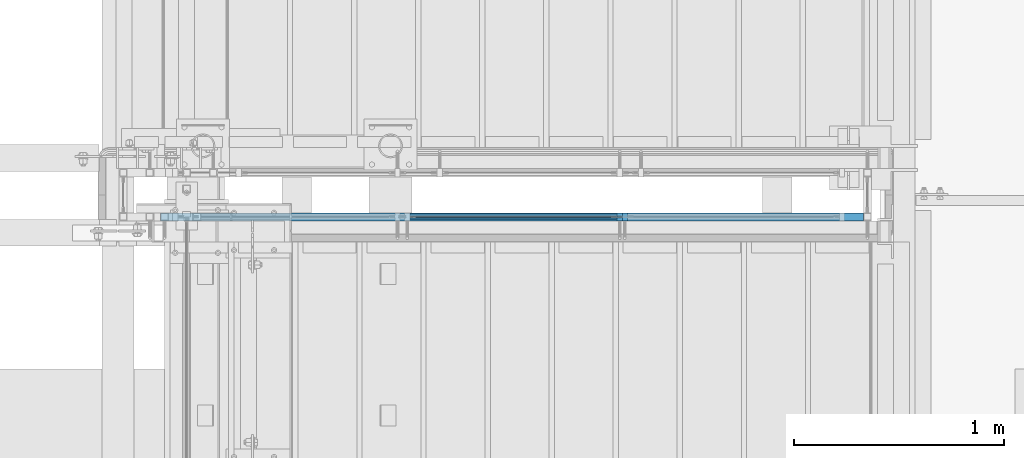
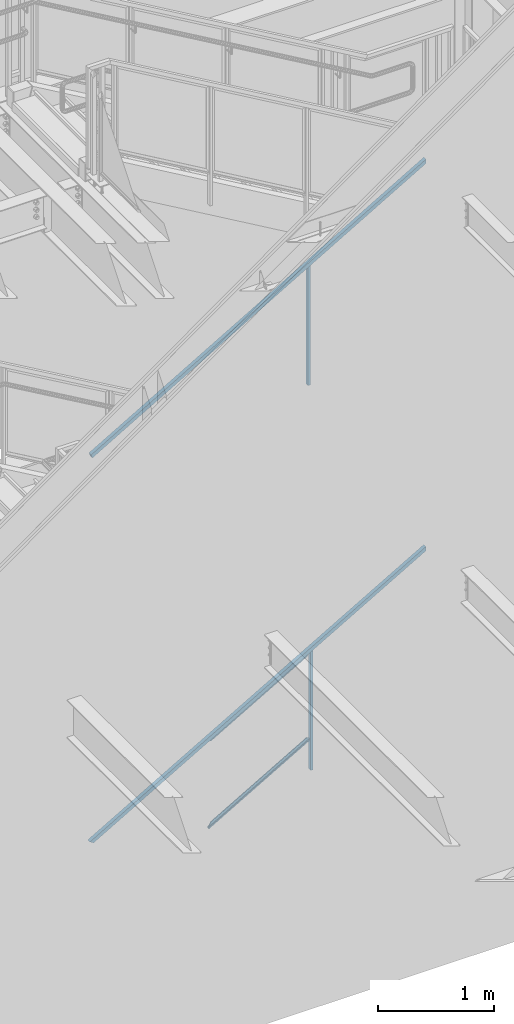
# One storey, part 783 of 1179: 5 members, 2 beams, 2 elements without a shape of their own.
"""IFC2X3 building model written with IfcOpenShell, lengths in millimetres."""

import ifcopenshell
import ifcopenshell.guid

model = None  # the IFC model being written
_history = None  # IfcOwnerHistory: only IFC2X3 demands one
_inside = {}  # id of a spatial element -> (the spatial element, [elements in it])
_under = {}  # id of a project, library or spatial element -> (it, [spatial elements below it])
_declared = {}  # id of a project -> (the project, [libraries it declares])
_typed = {}  # id of a type object -> (the type object, [elements of that type])
_made_of = {}  # id of a material, layer set ... -> (it, [elements and type objects made of it])


def new_model(schema):
    """Start an empty IFC model of exactly this schema.

    Asked for "IFC4X3", IfcOpenShell would pick the latest addendum, in which some entities
    have other attributes; the version numbers below select the first issue.
    IFC2X3 requires an IfcOwnerHistory on every rooted entity: one is made here for all.
    """
    global model, _history
    if schema == "IFC4X3":
        model = ifcopenshell.file(schema_version=(4, 3, 0, 0))
    else:
        model = ifcopenshell.file(schema=schema)
    _inside.clear()
    _under.clear()
    _declared.clear()
    _typed.clear()
    _made_of.clear()
    _history = None
    if model.schema == "IFC2X3":
        org = make("IfcOrganization", Name="unknown")
        user = make(
            "IfcPersonAndOrganization",
            ThePerson=make("IfcPerson", FamilyName="unknown"),
            TheOrganization=org,
        )
        app = make(
            "IfcApplication",
            ApplicationDeveloper=org,
            Version="unknown",
            ApplicationFullName="unknown",
            ApplicationIdentifier="unknown",
        )
        _history = make(
            "IfcOwnerHistory",
            OwningUser=user,
            OwningApplication=app,
            ChangeAction="ADDED",
            CreationDate=0,
        )
    return model


def make(cls, **values):
    """One entity of the class cls with the attributes given. An attribute that is None is left unset."""
    return model.create_entity(
        cls, **{name: value for name, value in values.items() if value is not None}
    )


def rooted(cls, **values):
    """An entity with a GlobalId (a new one), such as an element, a storey or a relation."""
    return make(cls, GlobalId=ifcopenshell.guid.new(), OwnerHistory=_history, **values)


def si_unit(unit_type, name, prefix=None):
    """IfcSIUnit, for example si_unit("LENGTHUNIT", "METRE", prefix="MILLI")."""
    return make("IfcSIUnit", UnitType=unit_type, Prefix=prefix, Name=name)


def assignment(units):
    """IfcUnitAssignment: the units of a project."""
    return None if units is None else make("IfcUnitAssignment", Units=units)


def point(xyz):
    """IfcCartesianPoint."""
    return None if xyz is None else make("IfcCartesianPoint", Coordinates=xyz)


def direction(xyz):
    """IfcDirection."""
    return None if xyz is None else make("IfcDirection", DirectionRatios=xyz)


def frame(location, z_axis=None, x_axis=None):
    """IfcAxis2Placement3D, a coordinate frame: its origin and axes. An axis left out is left unset."""
    return make(
        "IfcAxis2Placement3D",
        Location=point(location),
        Axis=direction(z_axis),
        RefDirection=direction(x_axis),
    )


def origin_with_axes():
    """The frame at (0, 0, 0) with the z axis (0, 0, 1) and the x axis (1, 0, 0) written out."""
    return frame((0.0, 0.0, 0.0), z_axis=(0.0, 0.0, 1.0), x_axis=(1.0, 0.0, 0.0))


def place(relative_to, where):
    """IfcLocalPlacement: puts the frame where relative to a parent placement (None: the world)."""
    return make(
        "IfcLocalPlacement", PlacementRelTo=relative_to, RelativePlacement=where
    )


def context(
    kind, dimensions, precision=None, world=None, true_north=None, identifier=None
):
    """IfcGeometricRepresentationContext, for example the 3D "Model" context."""
    return make(
        "IfcGeometricRepresentationContext",
        ContextIdentifier=identifier,
        ContextType=kind,
        CoordinateSpaceDimension=dimensions,
        Precision=precision,
        WorldCoordinateSystem=world,
        TrueNorth=true_north,
    )


def subcontext(parent, identifier, kind, view, scale=None):
    """IfcGeometricRepresentationSubContext, for example "Body" below "Model"."""
    return make(
        "IfcGeometricRepresentationSubContext",
        ContextIdentifier=identifier,
        ContextType=kind,
        ParentContext=parent,
        TargetScale=scale,
        TargetView=view,
    )


def project(units=None, contexts=None):
    """IfcProject with its units and contexts."""
    return rooted(
        "IfcProject",
        Name="project",
        RepresentationContexts=contexts,
        UnitsInContext=assignment(units),
    )


def spatial(cls, under=None, at=None, **own):
    """A site, building, storey or space (cls), placed at a placement, below another one or the project."""
    s = rooted(cls, ObjectPlacement=at, **own)
    if under is not None:
        _under.setdefault(under.id(), (under, []))[1].append(s)
    return s


def faces_of(points, faces, orient=None, outer=None):
    """IfcFace entities. A face is a list of loops; a loop is a list of indices into points, from 0.

    orient and outer hold one flag for each loop. By default every Orientation is true, the
    first loop of a face is its IfcFaceOuterBound and the others are IfcFaceBound.
    """
    made = []
    for i, loops in enumerate(faces):
        bounds = []
        for j, loop in enumerate(loops):
            is_outer = j == 0 if outer is None else outer[i][j]
            bounds.append(
                make(
                    "IfcFaceOuterBound" if is_outer else "IfcFaceBound",
                    Bound=make("IfcPolyLoop", Polygon=[points[k] for k in loop]),
                    Orientation=True if orient is None else orient[i][j],
                )
            )
        made.append(make("IfcFace", Bounds=bounds))
    return made


def faceted_brep(points, faces, orient=None, outer=None, voids=None):
    """IfcFacetedBrep: a solid bounded by flat faces; with voids (closed shells), ...WithVoids."""
    shared = [point(p) for p in points]
    hull = make("IfcClosedShell", CfsFaces=faces_of(shared, faces, orient, outer))
    if voids is None:
        return make("IfcFacetedBrep", Outer=hull)
    return make(
        "IfcFacetedBrepWithVoids",
        Outer=hull,
        Voids=[
            make(cls, CfsFaces=faces_of(shared, fs, o, b)) for cls, fs, o, b in voids
        ],
    )


def shape(context_of_items, identifier, shape_type, items):
    """IfcShapeRepresentation: the items that make up one representation, for example the "Body"."""
    return make(
        "IfcShapeRepresentation",
        ContextOfItems=context_of_items,
        RepresentationIdentifier=identifier,
        RepresentationType=shape_type,
        Items=items,
    )


def material(Name=None, Category=None):
    """IfcMaterial."""
    return make("IfcMaterial", Name=Name, Category=Category)


def made_of(thing, what):
    """Note that an element or type object is made of a material, layer set ...; save() writes the relation."""
    if what is not None:
        _made_of.setdefault(what.id(), (what, []))[1].append(thing)
    return thing


def type_object(cls, material=None, **own):
    """A type object (cls), such as IfcWallType, which elements share."""
    return made_of(rooted(cls, **own), material)


def element(
    cls,
    number,
    at=None,
    inside=None,
    cuts=None,
    type_object=None,
    material=None,
    context=None,
    identifier="Body",
    shape_type=None,
    held_by="IfcProductDefinitionShape",
    body=None,
    shapes=None,
    **own,
):
    """One element of the class cls, such as IfcWall. Its Tag is "e" and its number.

    at: its placement. inside: the storey or other place that contains it. cuts: it is an
    opening in that element (IfcRelVoidsElement). A single representation is given by context,
    identifier, shape_type and body (its items); several are given by shapes. held_by: the class
    of the entity that holds the representations. save() writes the other relations.
    """
    e = rooted(cls, Tag="e%d" % number, ObjectPlacement=at, **own)
    if body is not None:
        shapes = [shape(context, identifier, shape_type, body)]
    if shapes is not None:
        e.Representation = make(held_by, Representations=shapes)
    if inside is not None:
        _inside.setdefault(inside.id(), (inside, []))[1].append(e)
    if cuts is not None:
        rooted(
            "IfcRelVoidsElement", RelatingBuildingElement=cuts, RelatedOpeningElement=e
        )
    if type_object is not None:
        _typed.setdefault(type_object.id(), (type_object, []))[1].append(e)
    return made_of(e, material)


def aggregate(whole, parts):
    """IfcRelAggregates: a whole, such as a stair, and the parts it consists of."""
    return rooted("IfcRelAggregates", RelatingObject=whole, RelatedObjects=parts)


def save(model, path):
    """Write the relations noted so far, then the file.

    IfcRelAggregates (storeys below a building ...), IfcRelContainedInSpatialStructure (elements
    in a storey), IfcRelDefinesByType, IfcRelAssociatesMaterial and IfcRelDeclares: one each for
    every whole, place, type object, material and project.
    """
    for whole, parts in _under.values():
        aggregate(whole, parts)
    for where, things in _inside.values():
        rooted(
            "IfcRelContainedInSpatialStructure",
            RelatedElements=things,
            RelatingStructure=where,
        )
    for kind, things in _typed.values():
        rooted("IfcRelDefinesByType", RelatedObjects=things, RelatingType=kind)
    for what, things in _made_of.values():
        rooted("IfcRelAssociatesMaterial", RelatedObjects=things, RelatingMaterial=what)
    for by, libraries in _declared.values():
        rooted("IfcRelDeclares", RelatingContext=by, RelatedDefinitions=libraries)
    model.write(path)


model = new_model("IFC2X3")

# Units and contexts
model_context = context("Model", 3, precision=1e-05, world=origin_with_axes())
body_context = subcontext(model_context, "Body", "Model", "MODEL_VIEW")
ifc_project = project(units=[si_unit("LENGTHUNIT", "METRE", prefix="MILLI"), si_unit("AREAUNIT", "SQUARE_METRE"), si_unit("VOLUMEUNIT", "CUBIC_METRE"), si_unit("MASSUNIT", "GRAM", prefix="KILO"), si_unit("TIMEUNIT", "SECOND"), si_unit("PLANEANGLEUNIT", "RADIAN"), si_unit("SOLIDANGLEUNIT", "STERADIAN"), si_unit("THERMODYNAMICTEMPERATUREUNIT", "DEGREE_CELSIUS"), si_unit("LUMINOUSINTENSITYUNIT", "LUMEN")], contexts=[model_context])

# Site, building, storey
site_placement = place(None, origin_with_axes())
site = spatial("IfcSite", under=ifc_project, at=site_placement, CompositionType="ELEMENT")
building_placement = place(site_placement, origin_with_axes())
building = spatial("IfcBuilding", under=site, at=building_placement, Name="Undefined", CompositionType="ELEMENT")
storey_placement = place(building_placement, origin_with_axes())
storey = spatial("IfcBuildingStorey", under=building, at=storey_placement, Name="Undefined", CompositionType="ELEMENT", Elevation=0.0)

# Assembly, member
assembly_1_placement = place(storey_placement, origin_with_axes())
assembly_1 = element("IfcElementAssembly", 1, at=assembly_1_placement, inside=storey, Name="GUARDRAIL", AssemblyPlace="NOTDEFINED", PredefinedType="RIGID_FRAME")
ifc_material_1 = material(Name="STEEL/A36")
member_type_1 = type_object("IfcMemberType", PredefinedType="NOTDEFINED")
member_1_placement = place(assembly_1_placement, frame((21666.200000343, 39471.5999992249, 5292.73112112083), z_axis=(0.0, -1.0, 0.0), x_axis=(0.0, 0.0, 1.0)))
member_1 = element("IfcMember", 2, at=member_1_placement, type_object=member_type_1, material=ifc_material_1, Name="POST", context=body_context, shape_type="Brep", body=[
    faceted_brep([(0.0, 12.7000000000007, -19.0500000000029), (0.0, 12.7000000000007, 19.0500000000029), (1243.17712591994, 12.7000000000007, 19.0500000000029), (1243.17712591994, 12.7000000000007, -19.0500000000029), (0.0, -12.7000000000007, 19.0500000000029), (1257.99379259886, -12.7000000000007, 19.0500000000029), (0.0, -12.7000000000007, -19.0500000000029), (1257.99379259886, -12.7000000000007, -19.0500000000029)], [[[0, 1, 2, 3]], [[1, 4, 5, 2]], [[4, 6, 7, 5]], [[6, 0, 3, 7]], [[5, 7, 3, 2]], [[6, 4, 1, 0]]]),
])

# Assembly, member, beams
assembly_2_placement = place(storey_placement, origin_with_axes())
assembly_2 = element("IfcElementAssembly", 3, at=assembly_2_placement, inside=storey, Name="GUARDRAIL", AssemblyPlace="NOTDEFINED", PredefinedType="RIGID_FRAME")
member_2_placement = place(assembly_2_placement, frame((21689.4832588991, 39471.5999999818, 1238.22858513012), z_axis=(0.0, -1.0, 0.0), x_axis=(0.0, 0.0, 1.0)))
member_2 = element("IfcMember", 4, at=member_2_placement, type_object=member_type_1, material=ifc_material_1, Name="POST", context=body_context, shape_type="Brep", body=[
    faceted_brep([(0.0, 12.7000000000007, -19.0500000000029), (0.0, 12.7000000000007, 19.0500000000029), (1242.88603593101, 12.7000000000007, 19.0500000000029), (1242.88603593101, 12.7000000000007, -19.0500000000029), (0.0, -12.7000000000007, 19.0500000000029), (1257.59245954642, -12.7000000000007, 19.0500000000029), (0.0, -12.7000000000007, -19.0500000000029), (1257.59245954642, -12.7000000000007, -19.0500000000029)], [[[0, 1, 2, 3]], [[1, 4, 5, 2]], [[4, 6, 7, 5]], [[6, 0, 3, 7]], [[5, 7, 3, 2]], [[6, 4, 1, 0]]]),
])
ifc_material_2 = material(Name="STEEL/BUY-OUT")
beam_type = type_object("IfcBeamType", PredefinedType="NOTDEFINED")
beam_1_placement = place(assembly_2_placement, frame((21185.0984872739, 39468.4251653905, 2165.24787863395), z_axis=(-0.86540914081269, 0.0, -0.501065882891503), x_axis=(-0.501065882891504, 0.0, 0.86540914081269)))
beam_1 = element("IfcBeam", 5, at=beam_1_placement, type_object=beam_type, material=ifc_material_2, Name="U-EDGE", context=body_context, shape_type="Brep", body=[
    faceted_brep([(5.01850081491284e-07, 7.93750000584987, 565.654393641868), (5.01850081491284e-07, 4.76250000584696, 565.654393641868), (22.2250002528726, 4.76250000758591, 578.467765219681), (22.2250002588062, 1.58750000000146, 578.467765223097), (1.87355908565223e-09, 1.58750000000146, 565.654393353612), (1.87355908565223e-09, -1.58750000000146, 565.654393353612), (25.4000002588291, -1.58750000000146, 580.298246897597), (25.4000002528755, 7.93750000761065, 580.298246894159), (25.4000002430021, -1.58750000000146, -581.025000000453), (25.4000002489647, 7.9374999923748, -581.025000000533), (5.01226168125868e-07, 7.93749999444117, -536.968296245806), (5.01226168125868e-07, 4.76249999444553, -536.968296245806), (22.2250002489855, 4.76249999245192, -575.517911967814), (22.225000243081, 1.58750000000146, -575.51791195757), (-1.78260961547494e-09, 1.58750000000146, -536.968295373328), (-1.78260961547494e-09, -1.58750000000146, -536.968295373328)], [[[0, 1, 2, 3, 4, 5, 6, 7]], [[7, 6, 8, 9]], [[0, 7, 9, 10]], [[1, 0, 10, 11]], [[2, 1, 11, 12]], [[3, 2, 12, 13]], [[4, 3, 13, 14]], [[5, 4, 14, 15]], [[6, 5, 15, 8]], [[14, 13, 12, 11, 10, 9, 8, 15]]]),
])
beam_2_placement = place(assembly_2_placement, frame((21159.6443079872, 39468.4251653905, 1300.17743919132), z_axis=(-0.86540914081269, 0.0, -0.501065882891503), x_axis=(0.501065782098943, 0.0, -0.865409199170875)))
beam_2 = element("IfcBeam", 6, at=beam_2_placement, type_object=beam_type, material=ifc_material_2, Name="U-EDGE", context=body_context, shape_type="Brep", body=[
    faceted_brep([(-3.45607986673713e-10, 1.58750000000146, 536.241472034682), (-3.45607986673713e-10, -1.58750000000146, 536.241472034682), (22.2250001997436, -1.58750000000146, 574.791082474552), (22.2250002132259, -4.76249998287676, 574.791082497944), (4.30125510320067e-07, -4.76249998738058, 536.241472781338), (4.30125510320067e-07, -7.93749998737621, 536.241472781338), (25.400000213227, -7.93749998271232, 580.298169654056), (25.4000001996137, 1.58750000000146, 580.298169630441), (25.4000002140147, -7.93750001730223, -581.024999999514), (25.4000002276443, 1.58750000000146, -581.0249999997), (3.69254848919809e-10, 1.58750000000146, -566.38114146873), (3.69254848919809e-10, -1.58750000000146, -566.38114146873), (22.2250002275978, -1.58750000000146, -579.194516836025), (22.2250002140099, -4.76250001724839, -579.194516828193), (4.23933670390397e-07, -4.76250001332664, -566.381141712925), (4.23933670390397e-07, -7.93750001332955, -566.381141712925)], [[[0, 1, 2, 3, 4, 5, 6, 7]], [[7, 6, 8, 9]], [[0, 7, 9, 10]], [[1, 0, 10, 11]], [[2, 1, 11, 12]], [[3, 2, 12, 13]], [[4, 3, 13, 14]], [[5, 4, 14, 15]], [[6, 5, 15, 8]], [[14, 13, 12, 11, 10, 9, 8, 15]]]),
])

# Member
ifc_material_3 = material()
member_type_2 = type_object("IfcMemberType", Name="HSS1-1/2X1-1/2X1/8", PredefinedType="NOTDEFINED")
member_3_placement = place(assembly_1_placement, frame((19500.8500004143, 39471.5999992249, 5302.25), z_axis=(-0.503871025835012, 0.0, 0.86377890071706), x_axis=(0.863778900717086, 0.0, 0.503871025834967)))
member_3 = element("IfcMember", 7, at=member_3_placement, type_object=member_type_2, material=ifc_material_3, Name="GUARDRAIL", ObjectType="HSS1-1/2X1-1/2X1/8", context=body_context, shape_type="Brep", body=[
    faceted_brep([(3859.57996935167, -19.0500000000029, 19.0499992315645), (3837.35497022573, -19.0499992350015, -19.0499992383984), (3837.35497022573, 19.0499992350015, -19.0499992383984), (3859.57996935167, 19.0499992350015, 19.0499992315645), (3857.727886047, -15.874999282998, 15.8749992795665), (3857.727886047, 15.874999282998, 15.8749992795665), (3839.20705353487, 15.874999282998, -15.8749992864023), (3839.20705353487, -15.874999282998, -15.8749992864023), (5.15015095151102, 19.0499992350015, 19.0499992349869), (5.15015095151102, -19.0499992350015, 19.0499992349869), (-5.15015093865441, -19.0499992350015, -19.049999234986), (-5.15015093865441, 19.0499992350015, -19.049999234986), (4.29179243916951, 15.874999282998, 15.8749992829889), (4.29179243916951, -15.874999282998, 15.8749992829889), (-4.2917924263129, -15.874999282998, -15.8749992829908), (-4.2917924263129, 15.874999282998, -15.8749992829908)], [[[0, 1, 2, 3], [4, 5, 6, 7]], [[8, 9, 0, 3]], [[10, 11, 2, 1]], [[9, 10, 1, 0]], [[11, 8, 3, 2]], [[10, 9, 8, 11], [12, 13, 14, 15]], [[14, 13, 4, 7]], [[15, 14, 7, 6]], [[12, 15, 6, 5]], [[13, 12, 5, 4]]]),
])

aggregate(assembly_1, [member_1, member_3])

member_4_placement = place(assembly_2_placement, frame((19500.8500004143, 39471.5999999818, 1243.27708327978), z_axis=(-0.501065882891504, 0.0, 0.86540914081269), x_axis=(0.86540914081267, 0.0, 0.501065882891537)))
member_4 = element("IfcMember", 8, at=member_4_placement, type_object=member_type_2, material=ifc_material_3, Name="GUARDRAIL", ObjectType="HSS1-1/2X1-1/2X1/8", context=body_context, shape_type="Brep", body=[
    faceted_brep([(3852.24749121599, -19.0500000000029, 19.0499992332479), (3830.18785667868, -19.0499992350015, -19.049999236724), (3830.18785667868, 19.0499992350015, -19.049999236724), (3852.24749121599, 19.0499992350015, 19.0499992332516), (3850.40918829331, -15.874999282998, 15.8749992812536), (3850.40918829331, 15.874999282998, 15.8749992812536), (3832.02615960432, 15.874999282998, -15.8749992847243), (3832.02615960432, -15.874999282998, -15.8749992847243), (-10.9828913296587, 19.0499992350015, 19.049999234996), (-10.9828913296587, -19.0499992350015, 19.049999234996), (10.9828913387828, -19.0499992350015, -19.049999234996), (10.9828913387828, 19.0499992350015, -19.049999234996), (-9.15240939478463, 15.874999282998, 15.874999282998), (-9.15240939478463, -15.874999282998, 15.874999282998), (9.15240940391232, -15.874999282998, -15.874999282998), (9.15240940391232, 15.874999282998, -15.874999282998)], [[[0, 1, 2, 3], [4, 5, 6, 7]], [[8, 9, 0, 3]], [[10, 11, 2, 1]], [[9, 10, 1, 0]], [[11, 8, 3, 2]], [[10, 9, 8, 11], [12, 13, 14, 15]], [[14, 13, 4, 7]], [[15, 14, 7, 6]], [[12, 15, 6, 5]], [[13, 12, 5, 4]]]),
])

member_type_3 = type_object("IfcMemberType", PredefinedType="NOTDEFINED")
member_5_placement = place(assembly_2_placement, frame((20655.4916297385, 39471.5999999818, 969.74525582292), z_axis=(0.0, -1.0, 0.0), x_axis=(0.86540914081267, 0.0, 0.501065882891537)))
member_5 = element("IfcMember", 9, at=member_5_placement, type_object=member_type_3, material=ifc_material_1, Name="BOTTOM_RAIL", context=body_context, shape_type="Brep", body=[
    faceted_brep([(1183.80237647433, 6.34999999946194, 12.6999999999971), (1176.44916466662, -6.35000000052969, 12.6999999999971), (1176.44916466662, -6.35000000052969, -12.6999999999971), (1183.80237647433, 6.34999999946194, -12.6999999999971), (18.3517455546971, 6.34999999998763, 12.6999999999971), (18.3517455546971, 6.34999999998763, -12.6999999999971), (10.9985337469952, -6.35000000000582, -12.6999999999971), (10.9985337469952, -6.35000000000582, 12.6999999999971)], [[[0, 1, 2, 3]], [[4, 5, 6, 7]], [[5, 4, 0, 3]], [[6, 5, 3, 2]], [[7, 6, 2, 1]], [[4, 7, 1, 0]]]),
])

aggregate(assembly_2, [member_5, beam_1, beam_2, member_2, member_4])

save(model, "model.ifc")
